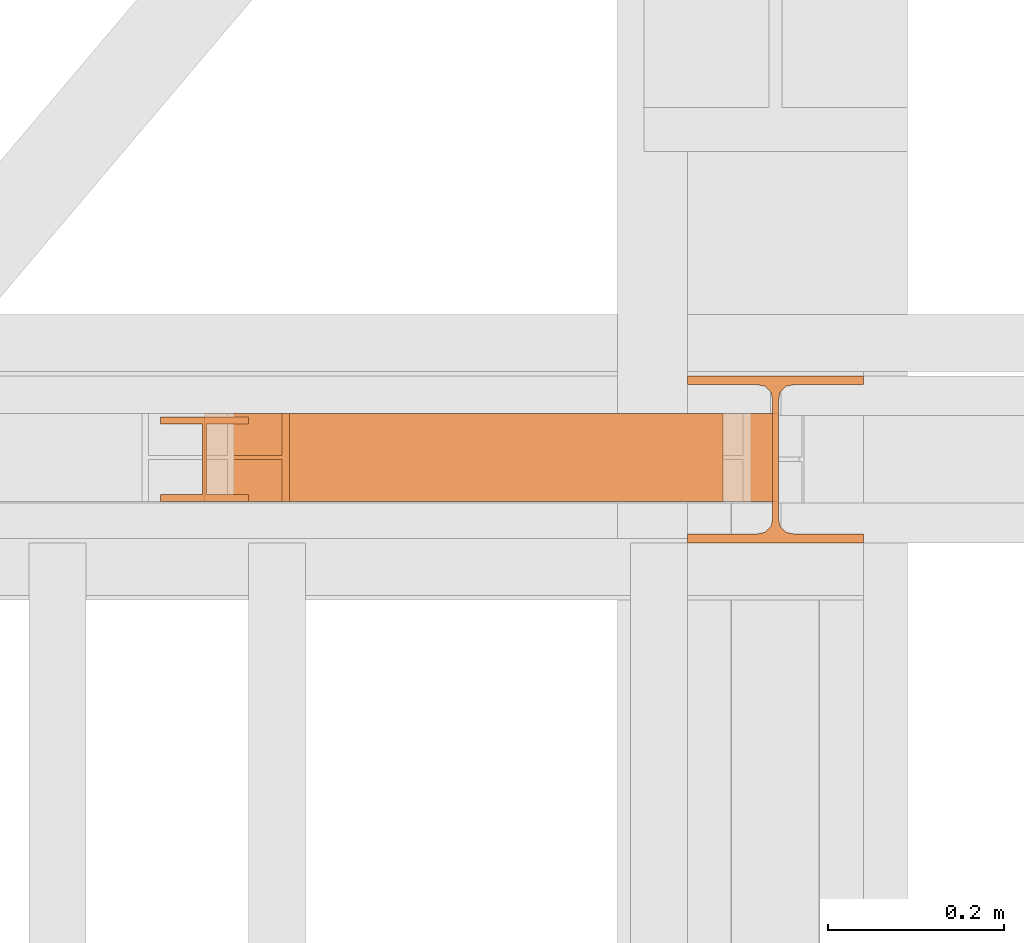
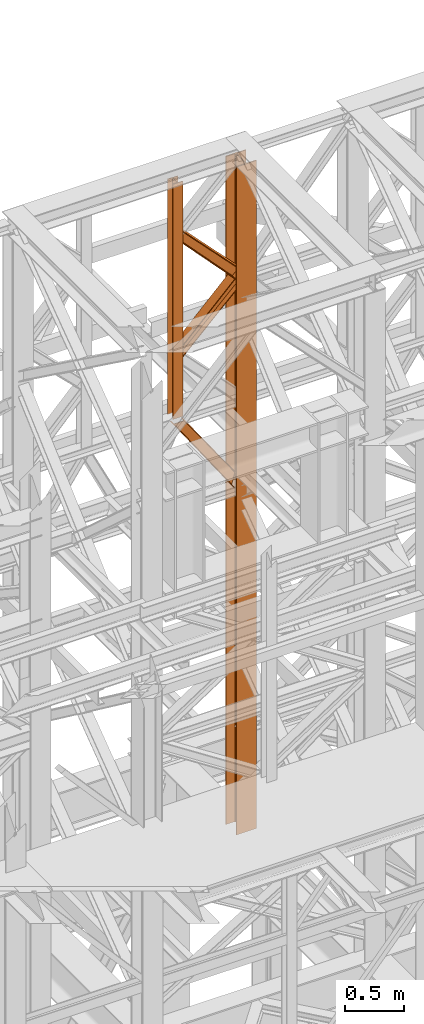
# One storey, part 165 of 208: 5 proxies.
"""IFC2X3 building model written with IfcOpenShell, lengths in millimetres."""

import ifcopenshell
import ifcopenshell.guid

model = None  # the IFC model being written
_history = None  # IfcOwnerHistory: only IFC2X3 demands one
_inside = {}  # id of a spatial element -> (the spatial element, [elements in it])
_under = {}  # id of a project, library or spatial element -> (it, [spatial elements below it])
_declared = {}  # id of a project -> (the project, [libraries it declares])
_typed = {}  # id of a type object -> (the type object, [elements of that type])
_made_of = {}  # id of a material, layer set ... -> (it, [elements and type objects made of it])


def new_model(schema):
    """Start an empty IFC model of exactly this schema.

    Asked for "IFC4X3", IfcOpenShell would pick the latest addendum, in which some entities
    have other attributes; the version numbers below select the first issue.
    IFC2X3 requires an IfcOwnerHistory on every rooted entity: one is made here for all.
    """
    global model, _history
    if schema == "IFC4X3":
        model = ifcopenshell.file(schema_version=(4, 3, 0, 0))
    else:
        model = ifcopenshell.file(schema=schema)
    _inside.clear()
    _under.clear()
    _declared.clear()
    _typed.clear()
    _made_of.clear()
    _history = None
    if model.schema == "IFC2X3":
        org = make("IfcOrganization", Name="unknown")
        user = make(
            "IfcPersonAndOrganization",
            ThePerson=make("IfcPerson", FamilyName="unknown"),
            TheOrganization=org,
        )
        app = make(
            "IfcApplication",
            ApplicationDeveloper=org,
            Version="unknown",
            ApplicationFullName="unknown",
            ApplicationIdentifier="unknown",
        )
        _history = make(
            "IfcOwnerHistory",
            OwningUser=user,
            OwningApplication=app,
            ChangeAction="ADDED",
            CreationDate=0,
        )
    return model


def make(cls, **values):
    """One entity of the class cls with the attributes given. An attribute that is None is left unset."""
    return model.create_entity(
        cls, **{name: value for name, value in values.items() if value is not None}
    )


def entity(cls, *values):
    """Any entity or typed value of the class cls, its attributes in the order of the schema. None: left unset."""
    e = model.create_entity(cls)
    for i, value in enumerate(values):
        if value is not None:
            e[i] = value
    return e


def rooted(cls, **values):
    """An entity with a GlobalId (a new one), such as an element, a storey or a relation."""
    return make(cls, GlobalId=ifcopenshell.guid.new(), OwnerHistory=_history, **values)


def si_unit(unit_type, name, prefix=None):
    """IfcSIUnit, for example si_unit("LENGTHUNIT", "METRE", prefix="MILLI")."""
    return make("IfcSIUnit", UnitType=unit_type, Prefix=prefix, Name=name)


def converted_unit(unit_type, name, factor, base, dimensions=None, offset=None):
    """IfcConversionBasedUnit, such as the inch: factor (a typed value) times the base unit."""
    return make(
        "IfcConversionBasedUnit"
        if offset is None
        else "IfcConversionBasedUnitWithOffset",
        ConversionOffset=offset,
        Dimensions=None
        if dimensions is None
        else entity("IfcDimensionalExponents", *dimensions),
        UnitType=unit_type,
        Name=name,
        ConversionFactor=make(
            "IfcMeasureWithUnit", ValueComponent=factor, UnitComponent=base
        ),
    )


def assignment(units):
    """IfcUnitAssignment: the units of a project."""
    return None if units is None else make("IfcUnitAssignment", Units=units)


def point(xyz):
    """IfcCartesianPoint."""
    return None if xyz is None else make("IfcCartesianPoint", Coordinates=xyz)


def direction(xyz):
    """IfcDirection."""
    return None if xyz is None else make("IfcDirection", DirectionRatios=xyz)


def frame(location, z_axis=None, x_axis=None):
    """IfcAxis2Placement3D, a coordinate frame: its origin and axes. An axis left out is left unset."""
    return make(
        "IfcAxis2Placement3D",
        Location=point(location),
        Axis=direction(z_axis),
        RefDirection=direction(x_axis),
    )


def origin():
    """The frame at (0, 0, 0) with its axes left unset."""
    return frame((0.0, 0.0, 0.0))


def origin_with_axes():
    """The frame at (0, 0, 0) with the z axis (0, 0, 1) and the x axis (1, 0, 0) written out."""
    return frame((0.0, 0.0, 0.0), z_axis=(0.0, 0.0, 1.0), x_axis=(1.0, 0.0, 0.0))


def place(relative_to, where):
    """IfcLocalPlacement: puts the frame where relative to a parent placement (None: the world)."""
    return make(
        "IfcLocalPlacement", PlacementRelTo=relative_to, RelativePlacement=where
    )


def context(
    kind, dimensions, precision=None, world=None, true_north=None, identifier=None
):
    """IfcGeometricRepresentationContext, for example the 3D "Model" context."""
    return make(
        "IfcGeometricRepresentationContext",
        ContextIdentifier=identifier,
        ContextType=kind,
        CoordinateSpaceDimension=dimensions,
        Precision=precision,
        WorldCoordinateSystem=world,
        TrueNorth=true_north,
    )


def subcontext(parent, identifier, kind, view, scale=None):
    """IfcGeometricRepresentationSubContext, for example "Body" below "Model"."""
    return make(
        "IfcGeometricRepresentationSubContext",
        ContextIdentifier=identifier,
        ContextType=kind,
        ParentContext=parent,
        TargetScale=scale,
        TargetView=view,
    )


def project(units=None, contexts=None):
    """IfcProject with its units and contexts."""
    return rooted(
        "IfcProject",
        Name="project",
        RepresentationContexts=contexts,
        UnitsInContext=assignment(units),
    )


def spatial(cls, under=None, at=None, **own):
    """A site, building, storey or space (cls), placed at a placement, below another one or the project."""
    s = rooted(cls, ObjectPlacement=at, **own)
    if under is not None:
        _under.setdefault(under.id(), (under, []))[1].append(s)
    return s


def faces_of(points, faces, orient=None, outer=None):
    """IfcFace entities. A face is a list of loops; a loop is a list of indices into points, from 0.

    orient and outer hold one flag for each loop. By default every Orientation is true, the
    first loop of a face is its IfcFaceOuterBound and the others are IfcFaceBound.
    """
    made = []
    for i, loops in enumerate(faces):
        bounds = []
        for j, loop in enumerate(loops):
            is_outer = j == 0 if outer is None else outer[i][j]
            bounds.append(
                make(
                    "IfcFaceOuterBound" if is_outer else "IfcFaceBound",
                    Bound=make("IfcPolyLoop", Polygon=[points[k] for k in loop]),
                    Orientation=True if orient is None else orient[i][j],
                )
            )
        made.append(make("IfcFace", Bounds=bounds))
    return made


def faceted_brep(points, faces, orient=None, outer=None, voids=None):
    """IfcFacetedBrep: a solid bounded by flat faces; with voids (closed shells), ...WithVoids."""
    shared = [point(p) for p in points]
    hull = make("IfcClosedShell", CfsFaces=faces_of(shared, faces, orient, outer))
    if voids is None:
        return make("IfcFacetedBrep", Outer=hull)
    return make(
        "IfcFacetedBrepWithVoids",
        Outer=hull,
        Voids=[
            make(cls, CfsFaces=faces_of(shared, fs, o, b)) for cls, fs, o, b in voids
        ],
    )


def shape(context_of_items, identifier, shape_type, items):
    """IfcShapeRepresentation: the items that make up one representation, for example the "Body"."""
    return make(
        "IfcShapeRepresentation",
        ContextOfItems=context_of_items,
        RepresentationIdentifier=identifier,
        RepresentationType=shape_type,
        Items=items,
    )


def made_of(thing, what):
    """Note that an element or type object is made of a material, layer set ...; save() writes the relation."""
    if what is not None:
        _made_of.setdefault(what.id(), (what, []))[1].append(thing)
    return thing


def element(
    cls,
    number,
    at=None,
    inside=None,
    cuts=None,
    type_object=None,
    material=None,
    context=None,
    identifier="Body",
    shape_type=None,
    held_by="IfcProductDefinitionShape",
    body=None,
    shapes=None,
    **own,
):
    """One element of the class cls, such as IfcWall. Its Tag is "e" and its number.

    at: its placement. inside: the storey or other place that contains it. cuts: it is an
    opening in that element (IfcRelVoidsElement). A single representation is given by context,
    identifier, shape_type and body (its items); several are given by shapes. held_by: the class
    of the entity that holds the representations. save() writes the other relations.
    """
    e = rooted(cls, Tag="e%d" % number, ObjectPlacement=at, **own)
    if body is not None:
        shapes = [shape(context, identifier, shape_type, body)]
    if shapes is not None:
        e.Representation = make(held_by, Representations=shapes)
    if inside is not None:
        _inside.setdefault(inside.id(), (inside, []))[1].append(e)
    if cuts is not None:
        rooted(
            "IfcRelVoidsElement", RelatingBuildingElement=cuts, RelatedOpeningElement=e
        )
    if type_object is not None:
        _typed.setdefault(type_object.id(), (type_object, []))[1].append(e)
    return made_of(e, material)


def aggregate(whole, parts):
    """IfcRelAggregates: a whole, such as a stair, and the parts it consists of."""
    return rooted("IfcRelAggregates", RelatingObject=whole, RelatedObjects=parts)


def save(model, path):
    """Write the relations noted so far, then the file.

    IfcRelAggregates (storeys below a building ...), IfcRelContainedInSpatialStructure (elements
    in a storey), IfcRelDefinesByType, IfcRelAssociatesMaterial and IfcRelDeclares: one each for
    every whole, place, type object, material and project.
    """
    for whole, parts in _under.values():
        aggregate(whole, parts)
    for where, things in _inside.values():
        rooted(
            "IfcRelContainedInSpatialStructure",
            RelatedElements=things,
            RelatingStructure=where,
        )
    for kind, things in _typed.values():
        rooted("IfcRelDefinesByType", RelatedObjects=things, RelatingType=kind)
    for what, things in _made_of.values():
        rooted("IfcRelAssociatesMaterial", RelatedObjects=things, RelatingMaterial=what)
    for by, libraries in _declared.values():
        rooted("IfcRelDeclares", RelatingContext=by, RelatedDefinitions=libraries)
    model.write(path)


model = new_model("IFC2X3")

# Units and contexts
model_context = context("Model", 3, precision=1e-05, world=origin())
plan_context = context("Plan", 3, precision=1e-05, world=origin())
body_context = subcontext(model_context, "Body", "Model", "MODEL_VIEW")
ifc_project = project(units=[si_unit("LENGTHUNIT", "METRE", prefix="MILLI"), converted_unit("PLANEANGLEUNIT", "DEGREE", entity("IfcPlaneAngleMeasure", 0.0174532925199433), si_unit("PLANEANGLEUNIT", "RADIAN"), dimensions=[0, 0, 0, 0, 0, 0, 0]), si_unit("AREAUNIT", "SQUARE_METRE"), si_unit("VOLUMEUNIT", "CUBIC_METRE")], contexts=[model_context, plan_context])

# Building, storey
building_placement = place(None, origin())
building = spatial("IfcBuilding", under=ifc_project, at=building_placement, CompositionType="COMPLEX")
storey_placement = place(building_placement, origin_with_axes())
storey = spatial("IfcBuildingStorey", under=building, at=storey_placement, Name="Geschoss", CompositionType="ELEMENT")

# Proxies
proxy_1_placement = place(storey_placement, frame((5393.254967038551, -13857.57439657637, 5284.990005364415), z_axis=(0.0, 0.0, 1.0), x_axis=(1.0, 0.0, 0.0)))
element("IfcBuildingElementProxy", 1, at=proxy_1_placement, inside=storey, context=body_context, shape_type="Brep", body=[
    faceted_brep([(0.01000000000021828, 190.0100125169756, 6965.010053329393), (200.0100029802325, 190.0100125169756, 6965.010053329393), (200.0100029802325, 180.0100146031382, 6965.010053329393), (121.2600035762789, 180.0100071525576, 6965.010053329393), (111.9441915473344, 178.1454621052744, 6965.010053329393), (105.1245498640838, 171.3258190250399, 6965.010053329393), (103.2600015571716, 162.010007927418, 6965.010053329393), (103.2600015571716, 28.00999713897727, 6965.010053329393), (105.1245498640838, 18.69418604135535, 6965.010053329393), (111.9441915473344, 11.87454296112082, 6965.010053329393), (121.2600035762789, 10.00999791383765, 6965.010053329393), (200.0100029802325, 10.00999791383765, 6965.010053329393), (200.0100029802325, 0.01000000000021828, 6965.010053329393), (0.01000000000021828, 0.01000000000021828, 6965.010053329393), (0.01000000000021828, 10.00999791383765, 6965.010053329393), (78.75999940395377, 10.00999791383765, 6965.010053329393), (88.07581143289826, 11.87454296112082, 6965.010053329393), (94.89545311614893, 18.69418604135535, 6965.010053329393), (96.76000142306111, 28.00999713897727, 6965.010053329393), (96.76000142306111, 162.010007927418, 6965.010053329393), (94.89545311614893, 171.3258190250399, 6965.010053329393), (88.07581143289826, 178.1454621052744, 6965.010053329393), (78.75999940395377, 180.0100071525576, 6965.010053329393), (0.01000000000021828, 180.0100146031382, 6965.010053329393), (200.0100029802325, 190.0100125169756, 6965.010053329393), (0.01000000000021828, 190.0100125169756, 6965.010053329393), (0.01000000000021828, 190.0100125169738, 0.01000000000112777), (200.0100029802325, 190.0100125169738, 0.01000000000112777), (200.0100029802325, 180.0100146031382, 6965.010053329393), (200.0100029802325, 190.0100125169756, 6965.010053329393), (200.0100029802325, 190.0100125169738, 0.01000000000112777), (200.0100029802325, 180.0100146031364, 0.01000000000112777), (121.2600035762789, 180.0100071525576, 6965.010053329393), (200.0100029802325, 180.0100146031382, 6965.010053329393), (200.0100029802325, 180.0100146031364, 0.01000000000112777), (121.2600035762789, 180.0100071525558, 0.01000000000112777), (111.9441915473344, 178.1454621052744, 6965.010053329393), (121.2600035762789, 180.0100071525576, 6965.010053329393), (121.2600035762789, 180.0100071525558, 0.01000000000112777), (111.9441915473344, 178.1454621052726, 0.01000000000112777), (105.1245498640838, 171.3258190250399, 6965.010053329393), (111.9441915473344, 178.1454621052744, 6965.010053329393), (111.9441915473344, 178.1454621052726, 0.01000000000112777), (105.1245498640838, 171.3258190250381, 0.01000000000112777), (103.2600015571716, 162.010007927418, 6965.010053329393), (105.1245498640838, 171.3258190250399, 6965.010053329393), (105.1245498640838, 171.3258190250381, 0.01000000000112777), (103.2600015571716, 162.0100079274162, 0.01000000000112777), (103.2600015571716, 28.00999713897727, 6965.010053329393), (103.2600015571716, 162.010007927418, 6965.010053329393), (103.2600015571716, 162.0100079274162, 0.01000000000112777), (103.2600015571716, 28.00999713897545, 0.01000000000112777), (105.1245498640838, 18.69418604135535, 6965.010053329393), (103.2600015571716, 28.00999713897727, 6965.010053329393), (103.2600015571716, 28.00999713897545, 0.01000000000112777), (105.1245498640838, 18.69418604135353, 0.01000000000112777), (111.9441915473344, 11.87454296112082, 6965.010053329393), (105.1245498640838, 18.69418604135535, 6965.010053329393), (105.1245498640838, 18.69418604135353, 0.01000000000112777), (111.9441915473344, 11.87454296111901, 0.01000000000112777), (121.2600035762789, 10.00999791383765, 6965.010053329393), (111.9441915473344, 11.87454296112082, 6965.010053329393), (111.9441915473344, 11.87454296111901, 0.01000000000112777), (121.2600035762789, 10.00999791383583, 0.01000000000112777), (200.0100029802325, 10.00999791383765, 6965.010053329393), (121.2600035762789, 10.00999791383765, 6965.010053329393), (121.2600035762789, 10.00999791383583, 0.01000000000112777), (200.0100029802325, 10.00999791383583, 0.01000000000112777), (200.0100029802325, 0.01000000000021828, 6965.010053329393), (200.0100029802325, 10.00999791383765, 6965.010053329393), (200.0100029802325, 10.00999791383583, 0.01000000000112777), (200.0100029802325, 0.00999999999839929, 0.01000000000112777), (0.01000000000021828, 0.01000000000021828, 6965.010053329393), (200.0100029802325, 0.01000000000021828, 6965.010053329393), (200.0100029802325, 0.00999999999839929, 0.01000000000112777), (0.01000000000021828, 0.00999999999839929, 0.01000000000112777), (0.01000000000021828, 10.00999791383765, 6965.010053329393), (0.01000000000021828, 0.01000000000021828, 6965.010053329393), (0.01000000000021828, 0.00999999999839929, 0.01000000000112777), (0.01000000000021828, 10.00999791383583, 0.01000000000112777), (78.75999940395377, 10.00999791383765, 6965.010053329393), (0.01000000000021828, 10.00999791383765, 6965.010053329393), (0.01000000000021828, 10.00999791383583, 0.01000000000112777), (78.75999940395377, 10.00999791383583, 0.01000000000112777), (88.07581143289826, 11.87454296112082, 6965.010053329393), (78.75999940395377, 10.00999791383765, 6965.010053329393), (78.75999940395377, 10.00999791383583, 0.01000000000112777), (88.07581143289826, 11.87454296111901, 0.01000000000112777), (94.89545311614893, 18.69418604135535, 6965.010053329393), (88.07581143289826, 11.87454296112082, 6965.010053329393), (88.07581143289826, 11.87454296111901, 0.01000000000112777), (94.89545311614893, 18.69418604135353, 0.01000000000112777), (96.76000142306111, 28.00999713897727, 6965.010053329393), (94.89545311614893, 18.69418604135535, 6965.010053329393), (94.89545311614893, 18.69418604135353, 0.01000000000112777), (96.76000142306111, 28.00999713897545, 0.01000000000112777), (96.76000142306111, 162.010007927418, 6965.010053329393), (96.76000142306111, 28.00999713897727, 6965.010053329393), (96.76000142306111, 28.00999713897545, 0.01000000000112777), (96.76000142306111, 162.0100079274162, 0.01000000000112777), (94.89545311614893, 171.3258190250399, 6965.010053329393), (96.76000142306111, 162.010007927418, 6965.010053329393), (96.76000142306111, 162.0100079274162, 0.01000000000112777), (94.89545311614893, 171.3258190250381, 0.01000000000112777), (88.07581143289826, 178.1454621052744, 6965.010053329393), (94.89545311614893, 171.3258190250399, 6965.010053329393), (94.89545311614893, 171.3258190250381, 0.01000000000112777), (88.07581143289826, 178.1454621052726, 0.01000000000112777), (78.75999940395377, 180.0100071525576, 6965.010053329393), (88.07581143289826, 178.1454621052744, 6965.010053329393), (88.07581143289826, 178.1454621052726, 0.01000000000112777), (78.75999940395377, 180.0100071525558, 0.01000000000112777), (0.01000000000021828, 180.0100146031382, 6965.010053329393), (78.75999940395377, 180.0100071525576, 6965.010053329393), (78.75999940395377, 180.0100071525558, 0.01000000000112777), (0.01000000000021828, 180.0100146031364, 0.01000000000112777), (0.01000000000021828, 190.0100125169756, 6965.010053329393), (0.01000000000021828, 180.0100146031382, 6965.010053329393), (0.01000000000021828, 180.0100146031364, 0.01000000000112777), (0.01000000000021828, 190.0100125169738, 0.01000000000112777), (0.01000000000021828, 190.0100125169738, 0.01000000000112777), (0.01000000000021828, 180.0100146031364, 0.01000000000112777), (78.75999940395377, 180.0100071525558, 0.01000000000112777), (88.07581143289826, 178.1454621052726, 0.01000000000112777), (94.89545311614893, 171.3258190250381, 0.01000000000112777), (96.76000142306111, 162.0100079274162, 0.01000000000112777), (96.76000142306111, 28.00999713897545, 0.01000000000112777), (94.89545311614893, 18.69418604135353, 0.01000000000112777), (88.07581143289826, 11.87454296111901, 0.01000000000112777), (78.75999940395377, 10.00999791383583, 0.01000000000112777), (0.01000000000021828, 10.00999791383583, 0.01000000000112777), (0.01000000000021828, 0.00999999999839929, 0.01000000000112777), (200.0100029802325, 0.00999999999839929, 0.01000000000112777), (200.0100029802325, 10.00999791383583, 0.01000000000112777), (121.2600035762789, 10.00999791383583, 0.01000000000112777), (111.9441915473344, 11.87454296111901, 0.01000000000112777), (105.1245498640838, 18.69418604135353, 0.01000000000112777), (103.2600015571716, 28.00999713897545, 0.01000000000112777), (103.2600015571716, 162.0100079274162, 0.01000000000112777), (105.1245498640838, 171.3258190250381, 0.01000000000112777), (111.9441915473344, 178.1454621052726, 0.01000000000112777), (121.2600035762789, 180.0100071525558, 0.01000000000112777), (200.0100029802325, 180.0100146031364, 0.01000000000112777), (200.0100029802325, 190.0100125169738, 0.01000000000112777)], [[[0, 1, 2, 3, 4, 5, 6, 7, 8, 9, 10, 11, 12, 13, 14, 15, 16, 17, 18, 19, 20, 21, 22, 23]], [[24, 25, 26, 27]], [[28, 29, 30, 31]], [[32, 33, 34, 35]], [[36, 37, 38, 39]], [[40, 41, 42, 43]], [[44, 45, 46, 47]], [[48, 49, 50, 51]], [[52, 53, 54, 55]], [[56, 57, 58, 59]], [[60, 61, 62, 63]], [[64, 65, 66, 67]], [[68, 69, 70, 71]], [[72, 73, 74, 75]], [[76, 77, 78, 79]], [[80, 81, 82, 83]], [[84, 85, 86, 87]], [[88, 89, 90, 91]], [[92, 93, 94, 95]], [[96, 97, 98, 99]], [[100, 101, 102, 103]], [[104, 105, 106, 107]], [[108, 109, 110, 111]], [[112, 113, 114, 115]], [[116, 117, 118, 119]], [[120, 121, 122, 123, 124, 125, 126, 127, 128, 129, 130, 131, 132, 133, 134, 135, 136, 137, 138, 139, 140, 141, 142, 143]]], orient=[[False], [False], [False], [False], [False], [False], [False], [False], [False], [False], [False], [False], [False], [False], [False], [False], [False], [False], [False], [False], [False], [False], [False], [False], [False], [False]]),
])
proxy_2_placement = place(storey_placement, frame((4793.254968528663, -13810.57439404318, 9798.105713222345), z_axis=(0.0, 0.0, 1.0), x_axis=(1.0, 0.0, 0.0)))
element("IfcBuildingElementProxy", 2, at=proxy_2_placement, inside=storey, context=body_context, shape_type="Brep", body=[
    faceted_brep([(100.0100000000039, 88.01000000000022, 0.01000000000021828), (100.0100000000039, 96.01000000000022, 0.01000000000021828), (0.01000000000385626, 96.01000000000022, 0.01000000000021828), (0.01000000000385626, 88.01000000000022, 0.01000000000021828), (47.51000000000386, 88.01000000000022, 0.01000000000021828), (47.51000000000386, 8.010000000000218, 0.01000000000021828), (0.01000000000385626, 8.010000000000218, 0.01000000000021828), (0.01000000000385626, 0.01000000000021828, 0.01000000000021828), (100.0100000000039, 0.01000000000021828, 0.01000000000021828), (100.0100000000039, 8.010000000000218, 0.01000000000021828), (52.51000000000386, 8.010000000000218, 0.01000000000021828), (52.51000000000386, 88.01000000000022, 0.01000000000021828), (100.0100000000039, 96.01000000000022, 0.01000000000021828), (100.0100000000039, 88.01000000000022, 0.01000000000021828), (100.0100000000002, 88.01000000000022, 2451.894345471463), (100.0100000000002, 96.01000000000022, 2451.894345471463), (0.01000000000385626, 96.01000000000022, 0.01000000000021828), (100.0100000000039, 96.01000000000022, 0.01000000000021828), (100.0100000000002, 96.01000000000022, 2451.894345471463), (0.01000000000021828, 96.01000000000022, 2451.894345471463), (0.01000000000385626, 88.01000000000022, 0.01000000000021828), (0.01000000000385626, 96.01000000000022, 0.01000000000021828), (0.01000000000021828, 96.01000000000022, 2451.894345471463), (0.01000000000021828, 88.01000000000022, 2451.894345471463), (47.51000000000386, 88.01000000000022, 0.01000000000021828), (0.01000000000385626, 88.01000000000022, 0.01000000000021828), (0.01000000000021828, 88.01000000000022, 2451.894345471463), (47.51000000000022, 88.01000000000022, 2451.894345471463), (47.51000000000386, 8.010000000000218, 0.01000000000021828), (47.51000000000386, 88.01000000000022, 0.01000000000021828), (47.51000000000022, 88.01000000000022, 2451.894345471463), (47.51000000000022, 8.010000000000218, 2451.894345471463), (0.01000000000385626, 8.010000000000218, 0.01000000000021828), (47.51000000000386, 8.010000000000218, 0.01000000000021828), (47.51000000000022, 8.010000000000218, 2451.894345471463), (0.01000000000021828, 8.010000000000218, 2451.894345471463), (0.01000000000385626, 0.01000000000021828, 0.01000000000021828), (0.01000000000385626, 8.010000000000218, 0.01000000000021828), (0.01000000000021828, 8.010000000000218, 2451.894345471463), (0.01000000000021828, 0.01000000000021828, 2451.894345471463), (100.0100000000039, 0.01000000000021828, 0.01000000000021828), (0.01000000000385626, 0.01000000000021828, 0.01000000000021828), (0.01000000000021828, 0.01000000000021828, 2451.894345471463), (100.0100000000002, 0.01000000000021828, 2451.894345471463), (100.0100000000039, 8.010000000000218, 0.01000000000021828), (100.0100000000039, 0.01000000000021828, 0.01000000000021828), (100.0100000000002, 0.01000000000021828, 2451.894345471463), (100.0100000000002, 8.010000000000218, 2451.894345471463), (52.51000000000386, 8.010000000000218, 0.01000000000021828), (100.0100000000039, 8.010000000000218, 0.01000000000021828), (100.0100000000002, 8.010000000000218, 2451.894345471463), (52.51000000000022, 8.010000000000218, 2451.894345471463), (52.51000000000386, 88.01000000000022, 0.01000000000021828), (52.51000000000386, 8.010000000000218, 0.01000000000021828), (52.51000000000022, 8.010000000000218, 2451.894345471463), (52.51000000000022, 88.01000000000022, 2451.894345471463), (100.0100000000039, 88.01000000000022, 0.01000000000021828), (52.51000000000386, 88.01000000000022, 0.01000000000021828), (52.51000000000022, 88.01000000000022, 2451.894345471463), (100.0100000000002, 88.01000000000022, 2451.894345471463), (100.0100000000002, 88.01000000000022, 2451.894345471463), (52.51000000000022, 88.01000000000022, 2451.894345471463), (52.51000000000022, 8.010000000000218, 2451.894345471463), (100.0100000000002, 8.010000000000218, 2451.894345471463), (100.0100000000002, 0.01000000000021828, 2451.894345471463), (0.01000000000021828, 0.01000000000021828, 2451.894345471463), (0.01000000000021828, 8.010000000000218, 2451.894345471463), (47.51000000000022, 8.010000000000218, 2451.894345471463), (47.51000000000022, 88.01000000000022, 2451.894345471463), (0.01000000000021828, 88.01000000000022, 2451.894345471463), (0.01000000000021828, 96.01000000000022, 2451.894345471463), (100.0100000000002, 96.01000000000022, 2451.894345471463)], [[[0, 1, 2, 3, 4, 5, 6, 7, 8, 9, 10, 11]], [[12, 13, 14, 15]], [[16, 17, 18, 19]], [[20, 21, 22, 23]], [[24, 25, 26, 27]], [[28, 29, 30, 31]], [[32, 33, 34, 35]], [[36, 37, 38, 39]], [[40, 41, 42, 43]], [[44, 45, 46, 47]], [[48, 49, 50, 51]], [[52, 53, 54, 55]], [[56, 57, 58, 59]], [[60, 61, 62, 63, 64, 65, 66, 67, 68, 69, 70, 71]]], orient=[[False], [False], [False], [False], [False], [False], [False], [False], [False], [False], [False], [False], [False], [False]]),
])
proxy_3_placement = place(storey_placement, frame((4845.754968528665, -13810.57439404318, 10955.2185593949), z_axis=(0.0, 0.0, 1.0), x_axis=(1.0, 0.0, 0.0)))
element("IfcBuildingElementProxy", 3, at=proxy_3_placement, inside=storey, context=body_context, shape_type="Brep", body=[
    faceted_brep([(647.5100014901182, 0.01000000000021828, 136.1559367639657), (0.01000000000203727, 0.01000000000021828, 810.8787261814559), (0.01000000000203727, 0.01000000000021828, 821.3321792650186), (647.5100014901182, 0.01000000000021828, 145.6651963377171), (647.5100014901182, 0.01000000000021828, 145.6651963377171), (0.01000000000203727, 0.01000000000021828, 821.3321792650186), (0.01000000000112777, 100.0100000000002, 821.3321792650258), (647.5100014901172, 100.0100000000002, 145.6651963377208), (647.5100014901172, 100.0100000000002, 145.6651963377208), (0.01000000000112777, 100.0100000000002, 821.3321792650258), (0.01000000000203727, 100.0100000000002, 810.8787261814559), (647.5100014901182, 100.0100000000002, 136.1559367639657), (647.5100014901182, 100.0100000000002, 136.1559367639657), (0.01000000000203727, 100.0100000000002, 810.8787261814559), (0.01000000000294676, 52.51000000000022, 810.8787261814559), (647.5100014901145, 52.51000000000022, 136.1559367639693), (647.5100014901145, 52.51000000000022, 136.1559367639693), (0.01000000000294676, 52.51000000000022, 810.8787261814559), (0.01000000000203727, 52.51000000000022, 700.4756203415545), (647.5100014901182, 52.51000000000022, 9.52026454738916), (647.5100014901182, 52.51000000000022, 9.52026454738916), (0.01000000000203727, 52.51000000000022, 700.4756203415545), (0.009999999999308784, 100.0100000000002, 700.4756203415545), (647.5100014901191, 100.0100000000002, 9.520264547385523), (647.5100014901191, 100.0100000000002, 9.520264547385523), (0.009999999999308784, 100.0100000000002, 700.4756203415545), (0.01000000000203727, 100.0100000000002, 690.0159394275852), (647.5100014901182, 100.0100000000002, 0.01000000000021828), (647.5100014901182, 100.0100000000002, 0.01000000000021828), (0.01000000000203727, 100.0100000000002, 690.0159394275852), (0.01000000000203727, 0.01000000000021828, 690.0159394275852), (647.5100014901182, 0.01000000000021828, 0.01000000000021828), (647.5100014901182, 0.01000000000021828, 0.01000000000021828), (0.01000000000203727, 0.01000000000021828, 690.0159394275852), (0.01000000000203727, 0.01000000000021828, 700.4756203415545), (647.5100014901182, 0.01000000000021828, 9.520264547392799), (647.5100014901182, 0.01000000000021828, 9.520264547392799), (0.01000000000203727, 0.01000000000021828, 700.4756203415545), (0.01000000000112777, 47.51000000000022, 700.4756203415545), (647.51000149012, 47.51000000000022, 9.520264547392799), (647.51000149012, 47.51000000000022, 9.520264547392799), (0.01000000000112777, 47.51000000000022, 700.4756203415545), (0.01000000000203727, 47.51000000000022, 810.8787261814559), (647.5100014901182, 47.51000000000022, 136.1559367639657), (647.5100014901182, 47.51000000000022, 136.1559367639657), (0.01000000000203727, 47.51000000000022, 810.8787261814559), (0.01000000000203727, 0.01000000000021828, 810.8787261814559), (647.5100014901182, 0.01000000000021828, 136.1559367639657), (0.01000000000203727, 0.01000000000021828, 810.8787261814559), (0.01000000000203727, 47.51000000000022, 810.8787261814559), (0.01000000000112777, 47.51000000000022, 700.4756203415545), (0.01000000000203727, 0.01000000000021828, 700.4756203415545), (0.01000000000203727, 0.01000000000021828, 690.0159394275852), (0.01000000000203727, 100.0100000000002, 690.0159394275852), (0.009999999999308784, 100.0100000000002, 700.4756203415545), (0.01000000000203727, 52.51000000000022, 700.4756203415545), (0.01000000000294676, 52.51000000000022, 810.8787261814559), (0.01000000000203727, 100.0100000000002, 810.8787261814559), (0.01000000000112777, 100.0100000000002, 821.3321792650258), (0.01000000000203727, 0.01000000000021828, 821.3321792650186), (647.5100014901182, 0.01000000000021828, 145.6651963377171), (647.5100014901172, 100.0100000000002, 145.6651963377208), (647.5100014901182, 100.0100000000002, 136.1559367639657), (647.5100014901145, 52.51000000000022, 136.1559367639693), (647.5100014901182, 52.51000000000022, 9.52026454738916), (647.5100014901191, 100.0100000000002, 9.520264547385523), (647.5100014901182, 100.0100000000002, 0.01000000000021828), (647.5100014901182, 0.01000000000021828, 0.01000000000021828), (647.5100014901182, 0.01000000000021828, 9.520264547392799), (647.51000149012, 47.51000000000022, 9.520264547392799), (647.5100014901182, 47.51000000000022, 136.1559367639657), (647.5100014901182, 0.01000000000021828, 136.1559367639657)], [[[0, 1, 2, 3]], [[4, 5, 6, 7]], [[8, 9, 10, 11]], [[12, 13, 14, 15]], [[16, 17, 18, 19]], [[20, 21, 22, 23]], [[24, 25, 26, 27]], [[28, 29, 30, 31]], [[32, 33, 34, 35]], [[36, 37, 38, 39]], [[40, 41, 42, 43]], [[44, 45, 46, 47]], [[48, 49, 50, 51, 52, 53, 54, 55, 56, 57, 58, 59]], [[60, 61, 62, 63, 64, 65, 66, 67, 68, 69, 70, 71]]], orient=[[False], [False], [False], [False], [False], [False], [False], [False], [False], [False], [False], [False], [False], [False]]),
])
proxy_4_placement = place(storey_placement, frame((4843.254968528662, -13810.57439404318, 10364.55433028874), z_axis=(0.0, 0.0, 1.0), x_axis=(1.0, 0.0, 0.0)))
element("IfcBuildingElementProxy", 4, at=proxy_4_placement, inside=storey, context=body_context, shape_type="Brep", body=[
    faceted_brep([(653.2600000670591, 0.01000000000021828, 771.736684541449), (0.01000000000294676, 0.01000000000021828, 117.0703501202133), (0.01000000000203727, 0.01000000000021828, 127.2232754441011), (653.2600000670591, 0.01000000000021828, 780.9755634240846), (653.2600000670591, 0.01000000000021828, 780.9755634240846), (0.01000000000203727, 0.01000000000021828, 127.2232754441011), (0.01000000000021828, 100.0100000000002, 127.2232754441011), (653.26000006706, 100.0100000000002, 780.9755634240883), (653.26000006706, 100.0100000000002, 780.9755634240883), (0.01000000000021828, 100.0100000000002, 127.2232754441011), (0.01000000000294676, 100.0100000000002, 117.0703501202133), (653.26000006706, 100.0100000000002, 771.7366845414454), (653.26000006706, 100.0100000000002, 771.7366845414454), (0.01000000000294676, 100.0100000000002, 117.0703501202133), (0.01000000000112777, 52.51000000000022, 117.0703501202133), (653.2600000670654, 52.51000000000022, 771.7366845414526), (653.2600000670654, 52.51000000000022, 771.7366845414526), (0.01000000000112777, 52.51000000000022, 117.0703501202133), (0.01000000000294676, 52.51000000000022, 10.10333120962423), (653.2600000670591, 52.51000000000022, 649.4102960638211), (653.2600000670591, 52.51000000000022, 649.4102960638211), (0.01000000000294676, 52.51000000000022, 10.10333120962423), (0.01000000000294676, 100.0100000000002, 10.10333120962787), (653.2600000670591, 100.0100000000002, 649.4102960638247), (653.2600000670591, 100.0100000000002, 649.4102960638247), (0.01000000000294676, 100.0100000000002, 10.10333120962787), (0.01000000000203727, 100.0100000000002, 0.01000000000385626), (653.26000006706, 100.0100000000002, 640.194998598121), (653.26000006706, 100.0100000000002, 640.194998598121), (0.01000000000203727, 100.0100000000002, 0.01000000000385626), (0.01000000000294676, 0.01000000000021828, 0.01000000000021828), (653.2600000670591, 0.01000000000021828, 640.194998598121), (653.2600000670591, 0.01000000000021828, 640.194998598121), (0.01000000000294676, 0.01000000000021828, 0.01000000000021828), (0.01000000000294676, 0.01000000000021828, 10.10333120962423), (653.2600000670591, 0.01000000000021828, 649.4102960638247), (653.2600000670591, 0.01000000000021828, 649.4102960638247), (0.01000000000294676, 0.01000000000021828, 10.10333120962423), (0.01000000000294676, 47.51000000000022, 10.10333120962787), (653.26000006706, 47.51000000000022, 649.4102960638284), (653.26000006706, 47.51000000000022, 649.4102960638284), (0.01000000000294676, 47.51000000000022, 10.10333120962787), (0.01000000000294676, 47.51000000000022, 117.0703501202133), (653.2600000670591, 47.51000000000022, 771.7366845414454), (653.2600000670591, 47.51000000000022, 771.7366845414454), (0.01000000000294676, 47.51000000000022, 117.0703501202133), (0.01000000000294676, 0.01000000000021828, 117.0703501202133), (653.2600000670591, 0.01000000000021828, 771.736684541449), (0.01000000000294676, 0.01000000000021828, 117.0703501202133), (0.01000000000294676, 47.51000000000022, 117.0703501202133), (0.01000000000294676, 47.51000000000022, 10.10333120962787), (0.01000000000294676, 0.01000000000021828, 10.10333120962423), (0.01000000000294676, 0.01000000000021828, 0.01000000000021828), (0.01000000000203727, 100.0100000000002, 0.01000000000385626), (0.01000000000294676, 100.0100000000002, 10.10333120962787), (0.01000000000294676, 52.51000000000022, 10.10333120962423), (0.01000000000112777, 52.51000000000022, 117.0703501202133), (0.01000000000294676, 100.0100000000002, 117.0703501202133), (0.01000000000021828, 100.0100000000002, 127.2232754441011), (0.01000000000203727, 0.01000000000021828, 127.2232754441011), (653.2600000670591, 0.01000000000021828, 780.9755634240846), (653.26000006706, 100.0100000000002, 780.9755634240883), (653.26000006706, 100.0100000000002, 771.7366845414454), (653.2600000670654, 52.51000000000022, 771.7366845414526), (653.2600000670591, 52.51000000000022, 649.4102960638211), (653.2600000670591, 100.0100000000002, 649.4102960638247), (653.26000006706, 100.0100000000002, 640.194998598121), (653.2600000670591, 0.01000000000021828, 640.194998598121), (653.2600000670591, 0.01000000000021828, 649.4102960638247), (653.26000006706, 47.51000000000022, 649.4102960638284), (653.2600000670591, 47.51000000000022, 771.7366845414454), (653.2600000670591, 0.01000000000021828, 771.736684541449)], [[[0, 1, 2, 3]], [[4, 5, 6, 7]], [[8, 9, 10, 11]], [[12, 13, 14, 15]], [[16, 17, 18, 19]], [[20, 21, 22, 23]], [[24, 25, 26, 27]], [[28, 29, 30, 31]], [[32, 33, 34, 35]], [[36, 37, 38, 39]], [[40, 41, 42, 43]], [[44, 45, 46, 47]], [[48, 49, 50, 51, 52, 53, 54, 55, 56, 57, 58, 59]], [[60, 61, 62, 63, 64, 65, 66, 67, 68, 69, 70, 71]]], orient=[[False], [False], [False], [False], [False], [False], [False], [False], [False], [False], [False], [False], [False], [False]]),
])
proxy_5_placement = place(storey_placement, frame((4823.735345452012, -13810.57439404318, 8872.310477686953), z_axis=(0.0, 0.0, 1.0), x_axis=(1.0, 0.0, 0.0)))
element("IfcBuildingElementProxy", 5, at=proxy_5_placement, inside=storey, context=body_context, shape_type="Brep", body=[
    faceted_brep([(607.5719637014754, 0.01000000000021828, 123.6259631817866), (107.9757067031342, 0.01000000000021828, 837.8052355353921), (116.3342395072814, 0.01000000000021828, 837.8052355353921), (609.6918638003699, 0.01000000000021828, 131.7181462696044), (609.6918638003699, 0.01000000000021828, 131.7181462696044), (116.3342395072814, 0.01000000000021828, 837.8052355353921), (116.3342395072787, 100.0100000000002, 837.8052355353921), (609.6918638003699, 100.0100000000002, 131.7181462696044), (609.6918638003699, 100.0100000000002, 131.7181462696044), (116.3342395072787, 100.0100000000002, 837.8052355353921), (107.9757067031342, 100.0100000000002, 837.8052355353921), (607.5719637014754, 100.0100000000002, 123.6259631817866), (607.5719637014754, 100.0100000000002, 123.6259631817866), (107.9757067031342, 100.0100000000002, 837.8052355353921), (107.9757067031324, 52.51000000000022, 837.8052355353921), (607.5719637014754, 52.51000000000022, 123.6259631817866), (607.5719637014754, 52.51000000000022, 123.6259631817866), (107.9757067031324, 52.51000000000022, 837.8052355353921), (8.346467362068324, 52.51000000000022, 837.8052355353921), (577.3079429277386, 52.51000000000022, 8.100709325468415), (577.3079429277386, 52.51000000000022, 8.100709325468415), (8.346467362068324, 52.51000000000022, 837.8052355353921), (8.346467362071962, 100.0100000000002, 837.8052355353921), (577.3079429277395, 100.0100000000002, 8.100709325472053), (577.3079429277395, 100.0100000000002, 8.100709325472053), (8.346467362071962, 100.0100000000002, 837.8052355353921), (0.01000000000112777, 100.0100000000002, 837.8052355353921), (575.1884289087111, 100.0100000000002, 0.01000000000021828), (575.1884289087111, 100.0100000000002, 0.01000000000021828), (0.01000000000112777, 100.0100000000002, 837.8052355353921), (0.009999999999308784, 0.01000000000021828, 837.8052355353921), (575.1884289087102, 0.01000000000021828, 0.01000000000021828), (575.1884289087102, 0.01000000000021828, 0.01000000000021828), (0.009999999999308784, 0.01000000000021828, 837.8052355353921), (8.346467362073781, 0.01000000000021828, 837.8052355353921), (577.3079429277395, 0.01000000000021828, 8.100709325472053), (577.3079429277395, 0.01000000000021828, 8.100709325472053), (8.346467362073781, 0.01000000000021828, 837.8052355353921), (8.346467362071962, 47.51000000000022, 837.8052355353884), (577.3079429277404, 47.51000000000022, 8.100709325475691), (577.3079429277404, 47.51000000000022, 8.100709325475691), (8.346467362071962, 47.51000000000022, 837.8052355353884), (107.9757067031342, 47.51000000000022, 837.8052355353921), (607.5719637014754, 47.51000000000022, 123.6259631817866), (607.5719637014754, 47.51000000000022, 123.6259631817866), (107.9757067031342, 47.51000000000022, 837.8052355353921), (107.9757067031342, 0.01000000000021828, 837.8052355353921), (607.5719637014754, 0.01000000000021828, 123.6259631817866), (609.6918638003699, 0.01000000000021828, 131.7181462696044), (609.6918638003699, 100.0100000000002, 131.7181462696044), (607.5719637014754, 100.0100000000002, 123.6259631817866), (607.5719637014754, 52.51000000000022, 123.6259631817866), (577.3079429277386, 52.51000000000022, 8.100709325468415), (577.3079429277395, 100.0100000000002, 8.100709325472053), (575.1884289087111, 100.0100000000002, 0.01000000000021828), (575.1884289087102, 0.01000000000021828, 0.01000000000021828), (577.3079429277395, 0.01000000000021828, 8.100709325472053), (577.3079429277404, 47.51000000000022, 8.100709325475691), (607.5719637014754, 47.51000000000022, 123.6259631817866), (607.5719637014754, 0.01000000000021828, 123.6259631817866), (107.9757067031342, 0.01000000000021828, 837.8052355353921), (107.9757067031342, 47.51000000000022, 837.8052355353921), (8.346467362071962, 47.51000000000022, 837.8052355353884), (8.346467362073781, 0.01000000000021828, 837.8052355353921), (0.009999999999308784, 0.01000000000021828, 837.8052355353921), (0.01000000000112777, 100.0100000000002, 837.8052355353921), (8.346467362071962, 100.0100000000002, 837.8052355353921), (8.346467362068324, 52.51000000000022, 837.8052355353921), (107.9757067031324, 52.51000000000022, 837.8052355353921), (107.9757067031342, 100.0100000000002, 837.8052355353921), (116.3342395072787, 100.0100000000002, 837.8052355353921), (116.3342395072814, 0.01000000000021828, 837.8052355353921)], [[[0, 1, 2, 3]], [[4, 5, 6, 7]], [[8, 9, 10, 11]], [[12, 13, 14, 15]], [[16, 17, 18, 19]], [[20, 21, 22, 23]], [[24, 25, 26, 27]], [[28, 29, 30, 31]], [[32, 33, 34, 35]], [[36, 37, 38, 39]], [[40, 41, 42, 43]], [[44, 45, 46, 47]], [[48, 49, 50, 51, 52, 53, 54, 55, 56, 57, 58, 59]], [[60, 61, 62, 63, 64, 65, 66, 67, 68, 69, 70, 71]]], orient=[[False], [False], [False], [False], [False], [False], [False], [False], [False], [False], [False], [False], [False], [False]]),
])

save(model, "model.ifc")
